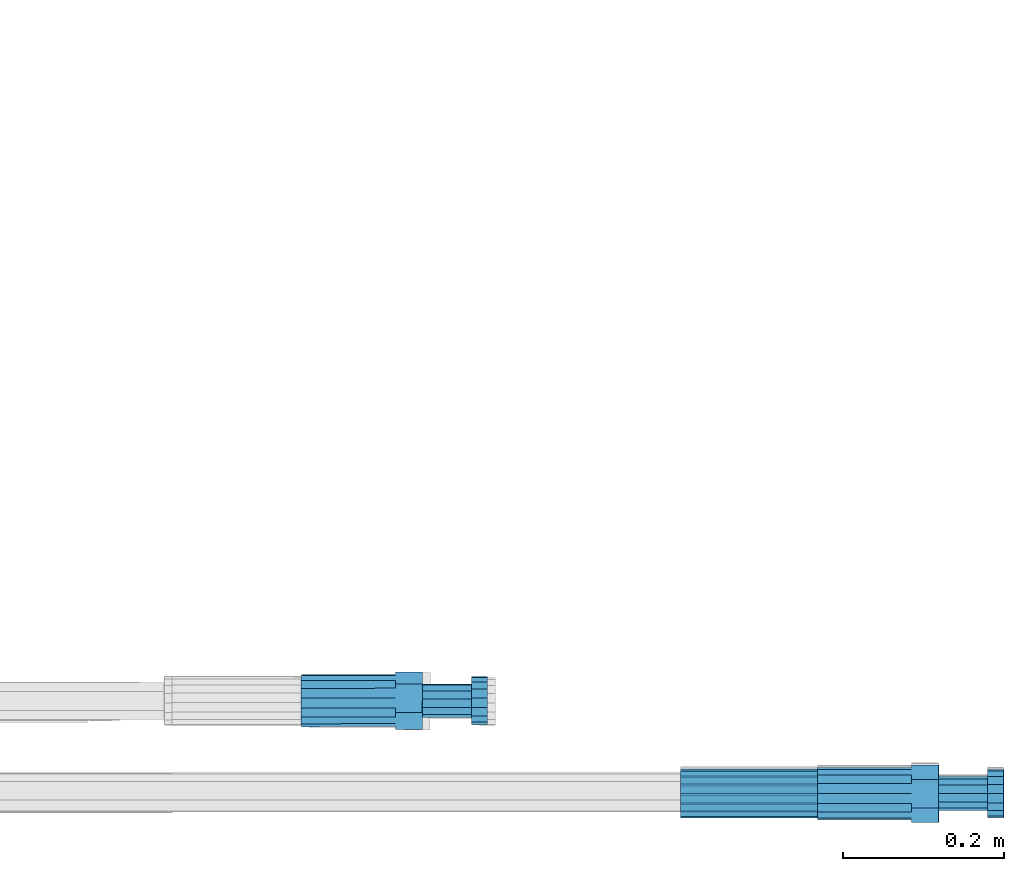
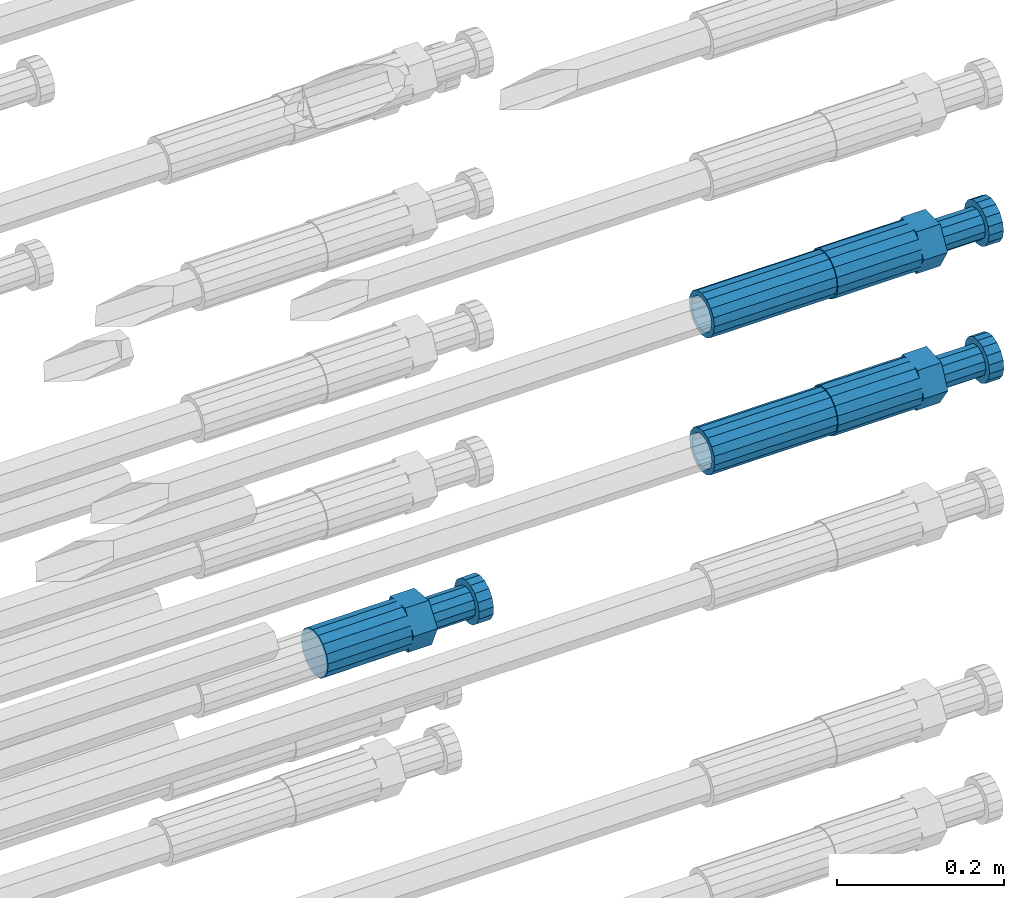
# One storey, part 104 of 177: 5 beams.
"""IFC2X3 building model written with IfcOpenShell, lengths in millimetres."""

from ifc_helpers import new_model, si_unit, frame, origin_with_axes, place, context, subcontext, project, spatial, faceted_brep, material, type_object, element, save


model = new_model("IFC2X3")

# Units and contexts
model_context_1 = context("Model", 3, precision=1e-05, world=origin_with_axes())
model_context_2 = context("Model", 3, precision=1e-05, world=origin_with_axes())
body_context = subcontext(model_context_2, "Body", "Model", "MODEL_VIEW")
ifc_project = project(units=[si_unit("LENGTHUNIT", "METRE", prefix="MILLI"), si_unit("AREAUNIT", "SQUARE_METRE"), si_unit("VOLUMEUNIT", "CUBIC_METRE"), si_unit("MASSUNIT", "GRAM", prefix="KILO"), si_unit("TIMEUNIT", "SECOND"), si_unit("PLANEANGLEUNIT", "RADIAN"), si_unit("SOLIDANGLEUNIT", "STERADIAN"), si_unit("THERMODYNAMICTEMPERATUREUNIT", "DEGREE_CELSIUS"), si_unit("LUMINOUSINTENSITYUNIT", "LUMEN")], contexts=[model_context_1])

# Site, building, storey
site_placement = place(None, origin_with_axes())
site = spatial("IfcSite", under=ifc_project, at=site_placement, CompositionType="ELEMENT")
building_placement = place(site_placement, origin_with_axes())
building = spatial("IfcBuilding", under=site, at=building_placement, Name="Undefined", CompositionType="ELEMENT")
storey_placement = place(building_placement, origin_with_axes())
storey = spatial("IfcBuildingStorey", under=building, at=storey_placement, Name="Undefined", CompositionType="ELEMENT", Elevation=0.0)

# Beams
ifc_material = material(Name="STEEL/S275")
beam_type_1 = type_object("IfcBeamType", PredefinedType="NOTDEFINED")
beam_1_placement = place(storey_placement, frame((2039349.01982224, 6205098.15705271, 20159.9789961903), z_axis=(0.0, 0.00575955399777739, -0.99998341363132), x_axis=(1.0, 0.0, 0.0)))
element("IfcBeam", 1, at=beam_1_placement, inside=storey, type_object=beam_type_1, material=ifc_material, Name="AG40N", context=body_context, shape_type="Brep", body=[
    faceted_brep([(0.0, -23.5000000001164, -9.31322574615479e-10), (0.0, -21.7111690140155, 8.99306066054851), (170.0, -21.7111690140155, 8.99306066054851), (170.0, -23.5, 0.0), (0.0, -16.6170093578839, 16.6170093575493), (170.0, -16.6170093578839, 16.6170093575493), (0.0, -8.99306066057943, 21.7111690137535), (170.0, -8.99306066057943, 21.7111690137535), (0.0, 1.16415321826935e-10, 23.5), (170.0, 0.0, 23.5), (0.0, 8.99306066057943, 21.7111690137535), (170.0, 8.99306066057943, 21.7111690137535), (0.0, 16.6170093578839, 16.6170093575493), (170.0, 16.6170093578839, 16.6170093575493), (0.0, 21.7111690140155, 8.99306066054851), (170.0, 21.7111690140155, 8.99306066054851), (0.0, 23.5000000001164, -9.31322574615479e-10), (170.0, 23.5, 0.0), (0.0, 21.7111690140155, -8.99306066054851), (170.0, 21.7111690140155, -8.99306066054851), (0.0, 16.6170093578839, -16.6170093575493), (170.0, 16.6170093578839, -16.6170093575493), (0.0, 8.99306066057943, -21.7111690137535), (170.0, 8.99306066057943, -21.7111690137535), (0.0, 1.16415321826935e-10, -23.5000000009313), (170.0, 0.0, -23.5), (0.0, -8.99306066057943, -21.7111690137535), (170.0, -8.99306066057943, -21.7111690137535), (0.0, -16.6170093578839, -16.6170093575493), (170.0, -16.6170093578839, -16.6170093575493), (0.0, -21.7111690140155, -8.99306066054851), (170.0, -21.7111690140155, -8.99306066054851), (0.0, -30.5, 0.0), (0.0, -28.1783257415937, -11.6718446873128), (170.0, -28.1783257415937, -11.6718446873128), (170.0, -30.5, 0.0), (0.0, -21.5667568261888, -21.5667568258941), (170.0, -21.5667568261888, -21.5667568258941), (0.0, -11.6718446871346, -28.1783257415518), (170.0, -11.6718446871346, -28.1783257415518), (0.0, 0.0, -30.5), (170.0, 0.0, -30.5), (0.0, 11.6718446871346, -28.1783257415518), (170.0, 11.6718446871346, -28.1783257415518), (0.0, 21.5667568261888, -21.5667568258941), (170.0, 21.5667568261888, -21.5667568258941), (0.0, 28.1783257415937, -11.6718446873128), (170.0, 28.1783257415937, -11.6718446873128), (0.0, 30.5, 0.0), (170.0, 30.5, 0.0), (0.0, 28.1783257415937, 11.6718446873128), (170.0, 28.1783257415937, 11.6718446873128), (0.0, 21.5667568261888, 21.5667568258941), (170.0, 21.5667568261888, 21.5667568258941), (0.0, 11.6718446871346, 28.1783257415518), (170.0, 11.6718446871346, 28.1783257415518), (0.0, 0.0, 30.5), (170.0, 0.0, 30.5), (0.0, -11.6718446871346, 28.1783257415518), (170.0, -11.6718446871346, 28.1783257415518), (0.0, -21.5667568261888, 21.5667568258941), (170.0, -21.5667568261888, 21.5667568258941), (0.0, -28.1783257415937, 11.6718446873128), (170.0, -28.1783257415937, 11.6718446873128)], [[[0, 1, 2, 3]], [[1, 4, 5, 2]], [[4, 6, 7, 5]], [[6, 8, 9, 7]], [[8, 10, 11, 9]], [[10, 12, 13, 11]], [[12, 14, 15, 13]], [[14, 16, 17, 15]], [[16, 18, 19, 17]], [[18, 20, 21, 19]], [[20, 22, 23, 21]], [[22, 24, 25, 23]], [[24, 26, 27, 25]], [[26, 28, 29, 27]], [[28, 30, 31, 29]], [[30, 0, 3, 31]], [[32, 33, 34, 35]], [[33, 36, 37, 34]], [[36, 38, 39, 37]], [[38, 40, 41, 39]], [[40, 42, 43, 41]], [[42, 44, 45, 43]], [[44, 46, 47, 45]], [[46, 48, 49, 47]], [[48, 50, 51, 49]], [[50, 52, 53, 51]], [[52, 54, 55, 53]], [[54, 56, 57, 55]], [[56, 58, 59, 57]], [[58, 60, 61, 59]], [[60, 62, 63, 61]], [[62, 32, 35, 63]], [[37, 39, 41, 43, 45, 47, 49, 51, 53, 55, 57, 59, 61, 63, 35, 34], [5, 7, 9, 11, 13, 15, 17, 19, 21, 23, 25, 27, 29, 31, 3, 2]], [[62, 60, 58, 56, 54, 52, 50, 48, 46, 44, 42, 40, 38, 36, 33, 32], [30, 28, 26, 24, 22, 20, 18, 16, 14, 12, 10, 8, 6, 4, 1, 0]]]),
])
beam_2_placement = place(storey_placement, frame((2039349.51584447, 6205098.0690342, 19959.1964578637), z_axis=(0.0, 0.069756474017166, -0.997564050240731), x_axis=(1.0, 0.0, 0.0)))
element("IfcBeam", 2, at=beam_2_placement, inside=storey, type_object=beam_type_1, material=ifc_material, Name="AG40N", context=body_context, shape_type="Brep", body=[
    faceted_brep([(0.0, -23.5000000001164, -9.31322574615479e-10), (0.0, -21.7111690140155, 8.99306066054851), (170.0, -21.7111690140155, 8.99306066054851), (170.0, -23.5, 0.0), (0.0, -16.6170093578839, 16.6170093575493), (170.0, -16.6170093578839, 16.6170093575493), (0.0, -8.99306066057943, 21.7111690137535), (170.0, -8.99306066057943, 21.7111690137535), (0.0, 1.16415321826935e-10, 23.5), (170.0, 0.0, 23.5), (0.0, 8.99306066057943, 21.7111690137535), (170.0, 8.99306066057943, 21.7111690137535), (0.0, 16.6170093578839, 16.6170093575493), (170.0, 16.6170093578839, 16.6170093575493), (0.0, 21.7111690140155, 8.99306066054851), (170.0, 21.7111690140155, 8.99306066054851), (0.0, 23.5000000001164, -9.31322574615479e-10), (170.0, 23.5, 0.0), (0.0, 21.7111690140155, -8.99306066054851), (170.0, 21.7111690140155, -8.99306066054851), (0.0, 16.6170093578839, -16.6170093575493), (170.0, 16.6170093578839, -16.6170093575493), (0.0, 8.99306066057943, -21.7111690137535), (170.0, 8.99306066057943, -21.7111690137535), (0.0, 1.16415321826935e-10, -23.5000000009313), (170.0, 0.0, -23.5), (0.0, -8.99306066057943, -21.7111690137535), (170.0, -8.99306066057943, -21.7111690137535), (0.0, -16.6170093578839, -16.6170093575493), (170.0, -16.6170093578839, -16.6170093575493), (0.0, -21.7111690140155, -8.99306066054851), (170.0, -21.7111690140155, -8.99306066054851), (0.0, -30.5, 0.0), (0.0, -28.1783257415937, -11.6718446873128), (170.0, -28.1783257415937, -11.6718446873128), (170.0, -30.5, 0.0), (0.0, -21.5667568261888, -21.5667568258941), (170.0, -21.5667568261888, -21.5667568258941), (0.0, -11.6718446871346, -28.1783257415518), (170.0, -11.6718446871346, -28.1783257415518), (0.0, 0.0, -30.5), (170.0, 0.0, -30.5), (0.0, 11.6718446871346, -28.1783257415518), (170.0, 11.6718446871346, -28.1783257415518), (0.0, 21.5667568261888, -21.5667568258941), (170.0, 21.5667568261888, -21.5667568258941), (0.0, 28.1783257415937, -11.6718446873128), (170.0, 28.1783257415937, -11.6718446873128), (0.0, 30.5, 0.0), (170.0, 30.5, 0.0), (0.0, 28.1783257415937, 11.6718446873128), (170.0, 28.1783257415937, 11.6718446873128), (0.0, 21.5667568261888, 21.5667568258941), (170.0, 21.5667568261888, 21.5667568258941), (0.0, 11.6718446871346, 28.1783257415518), (170.0, 11.6718446871346, 28.1783257415518), (0.0, 0.0, 30.5), (170.0, 0.0, 30.5), (0.0, -11.6718446871346, 28.1783257415518), (170.0, -11.6718446871346, 28.1783257415518), (0.0, -21.5667568261888, 21.5667568258941), (170.0, -21.5667568261888, 21.5667568258941), (0.0, -28.1783257415937, 11.6718446873128), (170.0, -28.1783257415937, 11.6718446873128)], [[[0, 1, 2, 3]], [[1, 4, 5, 2]], [[4, 6, 7, 5]], [[6, 8, 9, 7]], [[8, 10, 11, 9]], [[10, 12, 13, 11]], [[12, 14, 15, 13]], [[14, 16, 17, 15]], [[16, 18, 19, 17]], [[18, 20, 21, 19]], [[20, 22, 23, 21]], [[22, 24, 25, 23]], [[24, 26, 27, 25]], [[26, 28, 29, 27]], [[28, 30, 31, 29]], [[30, 0, 3, 31]], [[32, 33, 34, 35]], [[33, 36, 37, 34]], [[36, 38, 39, 37]], [[38, 40, 41, 39]], [[40, 42, 43, 41]], [[42, 44, 45, 43]], [[44, 46, 47, 45]], [[46, 48, 49, 47]], [[48, 50, 51, 49]], [[50, 52, 53, 51]], [[52, 54, 55, 53]], [[54, 56, 57, 55]], [[56, 58, 59, 57]], [[58, 60, 61, 59]], [[60, 62, 63, 61]], [[62, 32, 35, 63]], [[37, 39, 41, 43, 45, 47, 49, 51, 53, 55, 57, 59, 61, 63, 35, 34], [5, 7, 9, 11, 13, 15, 17, 19, 21, 23, 25, 27, 29, 31, 3, 2]], [[62, 60, 58, 56, 54, 52, 50, 48, 46, 44, 42, 40, 38, 36, 33, 32], [30, 28, 26, 24, 22, 20, 18, 16, 14, 12, 10, 8, 6, 4, 1, 0]]]),
])
beam_type_2 = type_object("IfcBeamType", Name="ROD65", PredefinedType="NOTDEFINED")
beam_3_placement = place(storey_placement, frame((2039519.01982224, 6205098.15705269, 20159.9789961879), z_axis=(0.0, 0.00575955399777739, -0.99998341363132), x_axis=(1.0, 0.0, 0.0)))
element("IfcBeam", 3, at=beam_3_placement, inside=storey, type_object=beam_type_2, material=ifc_material, Name="AGB40", ObjectType="ROD65", context=body_context, shape_type="Brep", body=[
    faceted_brep([(117.0, 8.17543110251427, 30.873805644922), (117.0, 17.8250000001863, 30.873805644922), (117.0, 22.0056958701462, 23.6326279877685), (117.0, 12.4372115517035, 30.0260848065373), (117.0, -17.8250000001863, 30.873805644922), (150.200000000186, -17.8250000001863, 30.873805644922), (150.200000000186, 17.8250000001863, 30.873805644922), (117.0, -8.17543110251427, 30.873805644922), (117.0, -12.4372115517035, 30.0260848065373), (117.0, -22.0056958701462, 23.6326279877685), (117.0, -35.6500000003725, 0.0), (150.200000000186, -35.6500000003725, 0.0), (117.0, -30.8443150008097, 8.32369058486074), (117.0, -32.5, 0.0), (117.0, -30.8443150008097, -8.32369058462791), (117.0, -17.8250000001863, -30.873805644922), (150.200000000186, -17.8250000001863, -30.873805644922), (117.0, -22.0056958701462, -23.6326279877685), (117.0, -12.4372115517035, -30.0260848065373), (117.0, -8.17543110251427, -30.873805644922), (117.0, 17.8250000001863, -30.873805644922), (150.200000000186, 17.8250000001863, -30.873805644922), (117.0, 8.17543110251427, -30.873805644922), (117.0, 22.0056958701462, -23.6326279877685), (117.0, 12.4372115517035, -30.0260848065373), (117.0, 35.6500000003725, 0.0), (150.200000000186, 35.6500000003725, 0.0), (117.0, 30.8443150008097, -8.32369058486074), (117.0, 30.8443150008097, 8.32369058462791), (117.0, 32.5, 0.0), (0.0, -22.9809703892097, 22.9809703885621), (0.0, -30.0260848058388, 12.4372115518636), (117.0, -30.0260848067701, 12.4372115519363), (117.0, -22.9809703882784, 22.9809703885112), (-2.3283064365387e-10, 22.9809703892097, -22.9809703885639), (-4.65661287307739e-10, 30.0260848077014, -12.4372115518672), (117.0, 30.0260848067701, -12.4372115519363), (117.0, 22.9809703882784, -22.9809703885112), (-2.3283064365387e-10, -30.0260848067701, -12.4372115518672), (-2.3283064365387e-10, -22.9809703892097, -22.9809703885621), (117.0, -22.9809703882784, -22.9809703885112), (117.0, -30.0260848067701, -12.4372115519363), (-2.3283064365387e-10, -12.4372115507722, 30.0260848066137), (-2.3283064365387e-10, 9.31322574615479e-10, 32.4999999999982), (-2.3283064365387e-10, 12.4372115526348, 30.0260848066137), (0.0, 22.9809703892097, 22.9809703885621), (-2.3283064365387e-10, 30.0260848077014, 12.4372115518636), (-2.3283064365387e-10, 32.5, 0.0), (-2.3283064365387e-10, 12.4372115526348, -30.0260848066173), (-2.3283064365387e-10, 9.31322574615479e-10, -32.5), (-2.3283064365387e-10, -12.4372115517035, -30.0260848066173), (-4.65661287307739e-10, -32.4999999990687, -1.81898940354586e-12), (117.0, 22.9809703882784, 22.9809703885112), (117.0, 30.0260848067701, 12.4372115519363), (117.0, 0.0, -32.5), (117.0, 0.0, 32.5), (150.200000000186, 10.5, -18.1865334794857), (150.200000000186, 0.0, -21.0), (150.200000000186, -10.5, -18.1865334794857), (150.200000000186, -18.18653347902, -10.5), (150.200000000186, -21.0, 0.0), (150.200000000186, -18.18653347902, 10.5), (150.200000000186, -10.5, 18.1865334794857), (150.200000000186, 0.0, 21.0), (150.200000000186, 10.5, 18.1865334794857), (150.200000000186, 18.18653347902, 10.5), (150.200000000186, 21.0, 0.0), (150.200000000186, 18.18653347902, -10.5), (210.980000000447, -18.18653347902, 10.5), (210.980000000447, -21.0, 0.0), (210.980000000447, -10.5, 18.1865334794857), (210.980000000447, 0.0, 21.0), (210.980000000447, 10.5, 18.1865334794857), (210.980000000447, 18.18653347902, 10.5), (210.980000000447, 21.0, 0.0), (210.980000000447, 18.18653347902, -10.5), (210.980000000447, 10.5, -18.1865334794857), (210.980000000447, 0.0, -21.0), (210.980000000447, -10.5, -18.1865334794857), (210.980000000447, -18.18653347902, -10.5), (211.001368442696, -27.7269937992096, -11.491116326768), (211.003082550167, -21.2238094303757, -21.223815418547), (231.002518367059, -21.2131944671273, -21.2132004550658), (231.000804259587, -27.7163788359612, -11.4805013632867), (211.001368440451, -11.4911085031927, -27.7269970395137), (231.000804257343, -11.4804935399443, -27.7163820760325), (210.996487071217, -0.0106065049767494, -30.0106107392348), (230.995922888109, 8.45827162265778e-06, -29.9999957757536), (210.989181586672, 11.46989420522, -27.7269970329944), (230.988617403564, 11.4805091684684, -27.7163820695132), (210.980564180623, 21.2025914648548, -21.2238154064398), (230.979999997515, 21.2132064281031, -21.2132004429586), (210.971946775022, 27.7057703435421, -11.4911163107026), (230.971382591913, 27.7163853067905, -11.4805013472214), (210.96464129175, 29.9893808094785, -0.0106149562634528), (230.964077108642, 29.9999957727268, 7.21774995326996e-09), (210.959759924415, 27.7057638689876, 11.4698863970116), (230.959195741307, 27.7163788322359, 11.4805013604928), (210.958045816944, 21.2025795001537, 21.2025854887906), (230.957481633835, 21.213194463402, 21.2132004522718), (210.95975992666, 11.4698785729706, 27.7057671097573), (230.959195743551, 11.480493536219, 27.7163820732385), (210.964641295894, -0.010623425245285, 29.9893808094785), (230.964077112785, -8.46199691295624e-06, 29.9999957729597), (210.971946780439, -11.4911241354421, 27.705767103238), (230.97138259733, -11.4805091721937, 27.7163820667192), (210.980564186488, -21.2238213950768, 21.2025854766835), (230.980000003379, -21.2132064318284, 21.2132004401647), (210.989181592089, -27.7270002737641, 11.4698863809463), (230.988617408981, -27.7163853105158, 11.4805013444275), (210.996487075361, -30.0106107397005, -0.0106149734929204), (230.995922892253, -29.9999957764521, -1.00117176771164e-08)], [[[0, 1, 2, 3]], [[4, 5, 6, 1, 0, 7]], [[4, 7, 8, 9]], [[10, 11, 5, 4, 9, 12]], [[10, 12, 13, 14]], [[15, 16, 11, 10, 14, 17]], [[15, 17, 18, 19]], [[20, 21, 16, 15, 19, 22]], [[23, 20, 22, 24]], [[25, 26, 21, 20, 23, 27]], [[28, 25, 27, 29]], [[30, 31, 32, 33]], [[34, 35, 36, 37]], [[38, 39, 40, 41]], [[31, 30, 42, 43, 44, 45, 46, 47, 35, 34, 48, 49, 50, 39, 38, 51]], [[46, 45, 52, 53]], [[29, 47, 46, 53, 28]], [[27, 36, 35, 47, 29]], [[23, 37, 36, 27]], [[24, 48, 34, 37, 23]], [[22, 54, 49, 48, 24]], [[19, 54, 22]], [[18, 50, 49, 54, 19]], [[17, 40, 39, 50, 18]], [[14, 41, 40, 17]], [[13, 51, 38, 41, 14]], [[12, 32, 31, 51, 13]], [[9, 33, 32, 12]], [[8, 42, 30, 33, 9]], [[7, 55, 43, 42, 8]], [[0, 55, 7]], [[3, 44, 43, 55, 0]], [[2, 52, 45, 44, 3]], [[28, 53, 52, 2]], [[1, 6, 26, 25, 28, 2]], [[5, 11, 16, 21, 26, 6], [56, 57, 58, 59, 60, 61, 62, 63, 64, 65, 66, 67]], [[68, 61, 60, 69]], [[70, 62, 61, 68]], [[71, 63, 62, 70]], [[72, 64, 63, 71]], [[73, 65, 64, 72]], [[74, 66, 65, 73]], [[75, 67, 66, 74]], [[76, 56, 67, 75]], [[77, 57, 56, 76]], [[78, 58, 57, 77]], [[79, 59, 58, 78]], [[69, 60, 59, 79]], [[80, 81, 82, 83]], [[81, 84, 85, 82]], [[84, 86, 87, 85]], [[86, 88, 89, 87]], [[88, 90, 91, 89]], [[90, 92, 93, 91]], [[92, 94, 95, 93]], [[94, 96, 97, 95]], [[96, 98, 99, 97]], [[98, 100, 101, 99]], [[100, 102, 103, 101]], [[102, 104, 105, 103]], [[104, 106, 107, 105]], [[106, 108, 109, 107]], [[108, 110, 111, 109]], [[82, 85, 87, 89, 91, 93, 95, 97, 99, 101, 103, 105, 107, 109, 111, 83]], [[110, 80, 83, 111]], [[108, 106, 104, 102, 100, 98, 96, 94, 92, 90, 88, 86, 84, 81, 80, 110], [75, 74, 73, 72, 71, 70, 68, 69, 79, 78, 77, 76]]]),
])
beam_4_placement = place(storey_placement, frame((2039519.51584447, 6205098.0690342, 19959.1964578637), z_axis=(0.0, 0.069756474017166, -0.997564050240731), x_axis=(1.0, 0.0, 0.0)))
element("IfcBeam", 4, at=beam_4_placement, inside=storey, type_object=beam_type_2, material=ifc_material, Name="AGB40", ObjectType="ROD65", context=body_context, shape_type="Brep", body=[
    faceted_brep([(117.0, 8.17543110251427, 30.873805644922), (117.0, 17.8250000001863, 30.873805644922), (117.0, 22.0056958701462, 23.6326279877685), (117.0, 12.4372115517035, 30.0260848065373), (117.0, -17.8250000001863, 30.873805644922), (150.200000000186, -17.8250000001863, 30.873805644922), (150.200000000186, 17.8250000001863, 30.873805644922), (117.0, -8.17543110251427, 30.873805644922), (117.0, -12.4372115517035, 30.0260848065373), (117.0, -22.0056958701462, 23.6326279877685), (117.0, -35.6500000003725, 0.0), (150.200000000186, -35.6500000003725, 0.0), (117.0, -30.8443150008097, 8.32369058486074), (117.0, -32.5, 0.0), (117.0, -30.8443150008097, -8.32369058462791), (117.0, -17.8250000001863, -30.873805644922), (150.200000000186, -17.8250000001863, -30.873805644922), (117.0, -22.0056958701462, -23.6326279877685), (117.0, -12.4372115517035, -30.0260848065373), (117.0, -8.17543110251427, -30.873805644922), (117.0, 17.8250000001863, -30.873805644922), (150.200000000186, 17.8250000001863, -30.873805644922), (117.0, 8.17543110251427, -30.873805644922), (117.0, 22.0056958701462, -23.6326279877685), (117.0, 12.4372115517035, -30.0260848065373), (117.0, 35.6500000003725, 0.0), (150.200000000186, 35.6500000003725, 0.0), (117.0, 30.8443150008097, -8.32369058486074), (117.0, 30.8443150008097, 8.32369058462791), (117.0, 32.5, 0.0), (0.0, -22.9809703892097, 22.9809703885621), (0.0, -30.0260848058388, 12.4372115518636), (117.0, -30.0260848067701, 12.4372115519363), (117.0, -22.9809703882784, 22.9809703885112), (-2.3283064365387e-10, 22.9809703892097, -22.9809703885639), (-4.65661287307739e-10, 30.0260848077014, -12.4372115518672), (117.0, 30.0260848067701, -12.4372115519363), (117.0, 22.9809703882784, -22.9809703885112), (-2.3283064365387e-10, -30.0260848067701, -12.4372115518672), (-2.3283064365387e-10, -22.9809703892097, -22.9809703885621), (117.0, -22.9809703882784, -22.9809703885112), (117.0, -30.0260848067701, -12.4372115519363), (-2.3283064365387e-10, -12.4372115507722, 30.0260848066137), (-2.3283064365387e-10, 9.31322574615479e-10, 32.4999999999982), (-2.3283064365387e-10, 12.4372115526348, 30.0260848066137), (0.0, 22.9809703892097, 22.9809703885621), (-2.3283064365387e-10, 30.0260848077014, 12.4372115518636), (-2.3283064365387e-10, 32.5, 0.0), (-2.3283064365387e-10, 12.4372115526348, -30.0260848066173), (-2.3283064365387e-10, 9.31322574615479e-10, -32.5), (-2.3283064365387e-10, -12.4372115517035, -30.0260848066173), (-4.65661287307739e-10, -32.4999999990687, -1.81898940354586e-12), (117.0, 22.9809703882784, 22.9809703885112), (117.0, 30.0260848067701, 12.4372115519363), (117.0, 0.0, -32.5), (117.0, 0.0, 32.5), (150.200000000186, 10.5, -18.1865334794857), (150.200000000186, 0.0, -21.0), (150.200000000186, -10.5, -18.1865334794857), (150.200000000186, -18.18653347902, -10.5), (150.200000000186, -21.0, 0.0), (150.200000000186, -18.18653347902, 10.5), (150.200000000186, -10.5, 18.1865334794857), (150.200000000186, 0.0, 21.0), (150.200000000186, 10.5, 18.1865334794857), (150.200000000186, 18.18653347902, 10.5), (150.200000000186, 21.0, 0.0), (150.200000000186, 18.18653347902, -10.5), (210.980000000447, -18.18653347902, 10.5), (210.980000000447, -21.0, 0.0), (210.980000000447, -10.5, 18.1865334794857), (210.980000000447, 0.0, 21.0), (210.980000000447, 10.5, 18.1865334794857), (210.980000000447, 18.18653347902, 10.5), (210.980000000447, 21.0, 0.0), (210.980000000447, 18.18653347902, -10.5), (210.980000000447, 10.5, -18.1865334794857), (210.980000000447, 0.0, -21.0), (210.980000000447, -10.5, -18.1865334794857), (210.980000000447, -18.18653347902, -10.5), (211.001368442696, -27.7269937992096, -11.491116326768), (211.003082550167, -21.2238094303757, -21.223815418547), (231.002518367059, -21.2131944671273, -21.2132004550658), (231.000804259587, -27.7163788359612, -11.4805013632867), (211.001368440451, -11.4911085031927, -27.7269970395137), (231.000804257343, -11.4804935399443, -27.7163820760325), (210.996487071217, -0.0106065049767494, -30.0106107392348), (230.995922888109, 8.45827162265778e-06, -29.9999957757536), (210.989181586672, 11.46989420522, -27.7269970329944), (230.988617403564, 11.4805091684684, -27.7163820695132), (210.980564180623, 21.2025914648548, -21.2238154064398), (230.979999997515, 21.2132064281031, -21.2132004429586), (210.971946775022, 27.7057703435421, -11.4911163107026), (230.971382591913, 27.7163853067905, -11.4805013472214), (210.96464129175, 29.9893808094785, -0.0106149562634528), (230.964077108642, 29.9999957727268, 7.21774995326996e-09), (210.959759924415, 27.7057638689876, 11.4698863970116), (230.959195741307, 27.7163788322359, 11.4805013604928), (210.958045816944, 21.2025795001537, 21.2025854887906), (230.957481633835, 21.213194463402, 21.2132004522718), (210.95975992666, 11.4698785729706, 27.7057671097573), (230.959195743551, 11.480493536219, 27.7163820732385), (210.964641295894, -0.010623425245285, 29.9893808094785), (230.964077112785, -8.46199691295624e-06, 29.9999957729597), (210.971946780439, -11.4911241354421, 27.705767103238), (230.97138259733, -11.4805091721937, 27.7163820667192), (210.980564186488, -21.2238213950768, 21.2025854766835), (230.980000003379, -21.2132064318284, 21.2132004401647), (210.989181592089, -27.7270002737641, 11.4698863809463), (230.988617408981, -27.7163853105158, 11.4805013444275), (210.996487075361, -30.0106107397005, -0.0106149734929204), (230.995922892253, -29.9999957764521, -1.00117176771164e-08)], [[[0, 1, 2, 3]], [[4, 5, 6, 1, 0, 7]], [[4, 7, 8, 9]], [[10, 11, 5, 4, 9, 12]], [[10, 12, 13, 14]], [[15, 16, 11, 10, 14, 17]], [[15, 17, 18, 19]], [[20, 21, 16, 15, 19, 22]], [[23, 20, 22, 24]], [[25, 26, 21, 20, 23, 27]], [[28, 25, 27, 29]], [[30, 31, 32, 33]], [[34, 35, 36, 37]], [[38, 39, 40, 41]], [[31, 30, 42, 43, 44, 45, 46, 47, 35, 34, 48, 49, 50, 39, 38, 51]], [[46, 45, 52, 53]], [[29, 47, 46, 53, 28]], [[27, 36, 35, 47, 29]], [[23, 37, 36, 27]], [[24, 48, 34, 37, 23]], [[22, 54, 49, 48, 24]], [[19, 54, 22]], [[18, 50, 49, 54, 19]], [[17, 40, 39, 50, 18]], [[14, 41, 40, 17]], [[13, 51, 38, 41, 14]], [[12, 32, 31, 51, 13]], [[9, 33, 32, 12]], [[8, 42, 30, 33, 9]], [[7, 55, 43, 42, 8]], [[0, 55, 7]], [[3, 44, 43, 55, 0]], [[2, 52, 45, 44, 3]], [[28, 53, 52, 2]], [[1, 6, 26, 25, 28, 2]], [[5, 11, 16, 21, 26, 6], [56, 57, 58, 59, 60, 61, 62, 63, 64, 65, 66, 67]], [[68, 61, 60, 69]], [[70, 62, 61, 68]], [[71, 63, 62, 70]], [[72, 64, 63, 71]], [[73, 65, 64, 72]], [[74, 66, 65, 73]], [[75, 67, 66, 74]], [[76, 56, 67, 75]], [[77, 57, 56, 76]], [[78, 58, 57, 77]], [[79, 59, 58, 78]], [[69, 60, 59, 79]], [[80, 81, 82, 83]], [[81, 84, 85, 82]], [[84, 86, 87, 85]], [[86, 88, 89, 87]], [[88, 90, 91, 89]], [[90, 92, 93, 91]], [[92, 94, 95, 93]], [[94, 96, 97, 95]], [[96, 98, 99, 97]], [[98, 100, 101, 99]], [[100, 102, 103, 101]], [[102, 104, 105, 103]], [[104, 106, 107, 105]], [[106, 108, 109, 107]], [[108, 110, 111, 109]], [[82, 85, 87, 89, 91, 93, 95, 97, 99, 101, 103, 105, 107, 109, 111, 83]], [[110, 80, 83, 111]], [[108, 106, 104, 102, 100, 98, 96, 94, 92, 90, 88, 86, 84, 81, 80, 110], [75, 74, 73, 72, 71, 70, 68, 69, 79, 78, 77, 76]]]),
])
beam_5_placement = place(storey_placement, frame((2038879.02867516, 6205213.28080054, 19758.3903732386), z_axis=(0.00670106952218352, -0.100912931037137, -0.994872693371746), x_axis=(0.999977413914641, 0.000161830002033731, 0.00671903799942243)))
element("IfcBeam", 5, at=beam_5_placement, inside=storey, type_object=beam_type_2, material=ifc_material, Name="AGB40", ObjectType="ROD65", context=body_context, shape_type="Brep", body=[
    faceted_brep([(117.0, 8.17543110251427, 30.873805644922), (117.0, 17.8250000001863, 30.873805644922), (117.0, 22.0056958701462, 23.6326279877685), (117.0, 12.4372115517035, 30.0260848065373), (117.0, -17.8250000001863, 30.873805644922), (150.200000000186, -17.8250000001863, 30.873805644922), (150.200000000186, 17.8250000001863, 30.873805644922), (117.0, -8.17543110251427, 30.873805644922), (117.0, -12.4372115517035, 30.0260848065373), (117.0, -22.0056958701462, 23.6326279877685), (117.0, -35.6500000003725, 0.0), (150.200000000186, -35.6500000003725, 0.0), (117.0, -30.8443150008097, 8.32369058486074), (117.0, -32.5, 0.0), (117.0, -30.8443150008097, -8.32369058462791), (117.0, -17.8250000001863, -30.873805644922), (150.200000000186, -17.8250000001863, -30.873805644922), (117.0, -22.0056958701462, -23.6326279877685), (117.0, -12.4372115517035, -30.0260848065373), (117.0, -8.17543110251427, -30.873805644922), (117.0, 17.8250000001863, -30.873805644922), (150.200000000186, 17.8250000001863, -30.873805644922), (117.0, 8.17543110251427, -30.873805644922), (117.0, 22.0056958701462, -23.6326279877685), (117.0, 12.4372115517035, -30.0260848065373), (117.0, 35.6500000003725, 0.0), (150.200000000186, 35.6500000003725, 0.0), (117.0, 30.8443150008097, -8.32369058486074), (117.0, 30.8443150008097, 8.32369058462791), (117.0, 32.5, 0.0), (0.0, -22.9809703892097, 22.9809703885621), (0.0, -30.0260848058388, 12.4372115518636), (117.0, -30.0260848067701, 12.4372115519363), (117.0, -22.9809703882784, 22.9809703885112), (-2.3283064365387e-10, 22.9809703892097, -22.9809703885639), (-4.65661287307739e-10, 30.0260848077014, -12.4372115518672), (117.0, 30.0260848067701, -12.4372115519363), (117.0, 22.9809703882784, -22.9809703885112), (-2.3283064365387e-10, -30.0260848067701, -12.4372115518672), (-2.3283064365387e-10, -22.9809703892097, -22.9809703885621), (117.0, -22.9809703882784, -22.9809703885112), (117.0, -30.0260848067701, -12.4372115519363), (-2.3283064365387e-10, -12.4372115507722, 30.0260848066137), (-2.3283064365387e-10, 9.31322574615479e-10, 32.4999999999982), (-2.3283064365387e-10, 12.4372115526348, 30.0260848066137), (0.0, 22.9809703892097, 22.9809703885621), (-2.3283064365387e-10, 30.0260848077014, 12.4372115518636), (-2.3283064365387e-10, 32.5, 0.0), (-2.3283064365387e-10, 12.4372115526348, -30.0260848066173), (-2.3283064365387e-10, 9.31322574615479e-10, -32.5), (-2.3283064365387e-10, -12.4372115517035, -30.0260848066173), (-4.65661287307739e-10, -32.4999999990687, -1.81898940354586e-12), (117.0, 22.9809703882784, 22.9809703885112), (117.0, 30.0260848067701, 12.4372115519363), (117.0, 0.0, -32.5), (117.0, 0.0, 32.5), (150.200000000186, 10.5, -18.1865334794857), (150.200000000186, 0.0, -21.0), (150.200000000186, -10.5, -18.1865334794857), (150.200000000186, -18.18653347902, -10.5), (150.200000000186, -21.0, 0.0), (150.200000000186, -18.18653347902, 10.5), (150.200000000186, -10.5, 18.1865334794857), (150.200000000186, 0.0, 21.0), (150.200000000186, 10.5, 18.1865334794857), (150.200000000186, 18.18653347902, 10.5), (150.200000000186, 21.0, 0.0), (150.200000000186, 18.18653347902, -10.5), (210.980000000447, -18.18653347902, 10.5), (210.980000000447, -21.0, 0.0), (210.980000000447, -10.5, 18.1865334794857), (210.980000000447, 0.0, 21.0), (210.980000000447, 10.5, 18.1865334794857), (210.980000000447, 18.18653347902, 10.5), (210.980000000447, 21.0, 0.0), (210.980000000447, 18.18653347902, -10.5), (210.980000000447, 10.5, -18.1865334794857), (210.980000000447, 0.0, -21.0), (210.980000000447, -10.5, -18.1865334794857), (210.980000000447, -18.18653347902, -10.5), (211.001368442696, -27.7269937992096, -11.491116326768), (211.003082550167, -21.2238094303757, -21.223815418547), (231.002518367059, -21.2131944671273, -21.2132004550658), (231.000804259587, -27.7163788359612, -11.4805013632867), (211.001368440451, -11.4911085031927, -27.7269970395137), (231.000804257343, -11.4804935399443, -27.7163820760325), (210.996487071217, -0.0106065049767494, -30.0106107392348), (230.995922888109, 8.45827162265778e-06, -29.9999957757536), (210.989181586672, 11.46989420522, -27.7269970329944), (230.988617403564, 11.4805091684684, -27.7163820695132), (210.980564180623, 21.2025914648548, -21.2238154064398), (230.979999997515, 21.2132064281031, -21.2132004429586), (210.971946775022, 27.7057703435421, -11.4911163107026), (230.971382591913, 27.7163853067905, -11.4805013472214), (210.96464129175, 29.9893808094785, -0.0106149562634528), (230.964077108642, 29.9999957727268, 7.21774995326996e-09), (210.959759924415, 27.7057638689876, 11.4698863970116), (230.959195741307, 27.7163788322359, 11.4805013604928), (210.958045816944, 21.2025795001537, 21.2025854887906), (230.957481633835, 21.213194463402, 21.2132004522718), (210.95975992666, 11.4698785729706, 27.7057671097573), (230.959195743551, 11.480493536219, 27.7163820732385), (210.964641295894, -0.010623425245285, 29.9893808094785), (230.964077112785, -8.46199691295624e-06, 29.9999957729597), (210.971946780439, -11.4911241354421, 27.705767103238), (230.97138259733, -11.4805091721937, 27.7163820667192), (210.980564186488, -21.2238213950768, 21.2025854766835), (230.980000003379, -21.2132064318284, 21.2132004401647), (210.989181592089, -27.7270002737641, 11.4698863809463), (230.988617408981, -27.7163853105158, 11.4805013444275), (210.996487075361, -30.0106107397005, -0.0106149734929204), (230.995922892253, -29.9999957764521, -1.00117176771164e-08)], [[[0, 1, 2, 3]], [[4, 5, 6, 1, 0, 7]], [[4, 7, 8, 9]], [[10, 11, 5, 4, 9, 12]], [[10, 12, 13, 14]], [[15, 16, 11, 10, 14, 17]], [[15, 17, 18, 19]], [[20, 21, 16, 15, 19, 22]], [[23, 20, 22, 24]], [[25, 26, 21, 20, 23, 27]], [[28, 25, 27, 29]], [[30, 31, 32, 33]], [[34, 35, 36, 37]], [[38, 39, 40, 41]], [[31, 30, 42, 43, 44, 45, 46, 47, 35, 34, 48, 49, 50, 39, 38, 51]], [[46, 45, 52, 53]], [[29, 47, 46, 53, 28]], [[27, 36, 35, 47, 29]], [[23, 37, 36, 27]], [[24, 48, 34, 37, 23]], [[22, 54, 49, 48, 24]], [[19, 54, 22]], [[18, 50, 49, 54, 19]], [[17, 40, 39, 50, 18]], [[14, 41, 40, 17]], [[13, 51, 38, 41, 14]], [[12, 32, 31, 51, 13]], [[9, 33, 32, 12]], [[8, 42, 30, 33, 9]], [[7, 55, 43, 42, 8]], [[0, 55, 7]], [[3, 44, 43, 55, 0]], [[2, 52, 45, 44, 3]], [[28, 53, 52, 2]], [[1, 6, 26, 25, 28, 2]], [[5, 11, 16, 21, 26, 6], [56, 57, 58, 59, 60, 61, 62, 63, 64, 65, 66, 67]], [[68, 61, 60, 69]], [[70, 62, 61, 68]], [[71, 63, 62, 70]], [[72, 64, 63, 71]], [[73, 65, 64, 72]], [[74, 66, 65, 73]], [[75, 67, 66, 74]], [[76, 56, 67, 75]], [[77, 57, 56, 76]], [[78, 58, 57, 77]], [[79, 59, 58, 78]], [[69, 60, 59, 79]], [[80, 81, 82, 83]], [[81, 84, 85, 82]], [[84, 86, 87, 85]], [[86, 88, 89, 87]], [[88, 90, 91, 89]], [[90, 92, 93, 91]], [[92, 94, 95, 93]], [[94, 96, 97, 95]], [[96, 98, 99, 97]], [[98, 100, 101, 99]], [[100, 102, 103, 101]], [[102, 104, 105, 103]], [[104, 106, 107, 105]], [[106, 108, 109, 107]], [[108, 110, 111, 109]], [[82, 85, 87, 89, 91, 93, 95, 97, 99, 101, 103, 105, 107, 109, 111, 83]], [[110, 80, 83, 111]], [[108, 106, 104, 102, 100, 98, 96, 94, 92, 90, 88, 86, 84, 81, 80, 110], [75, 74, 73, 72, 71, 70, 68, 69, 79, 78, 77, 76]]]),
])

save(model, "model.ifc")
